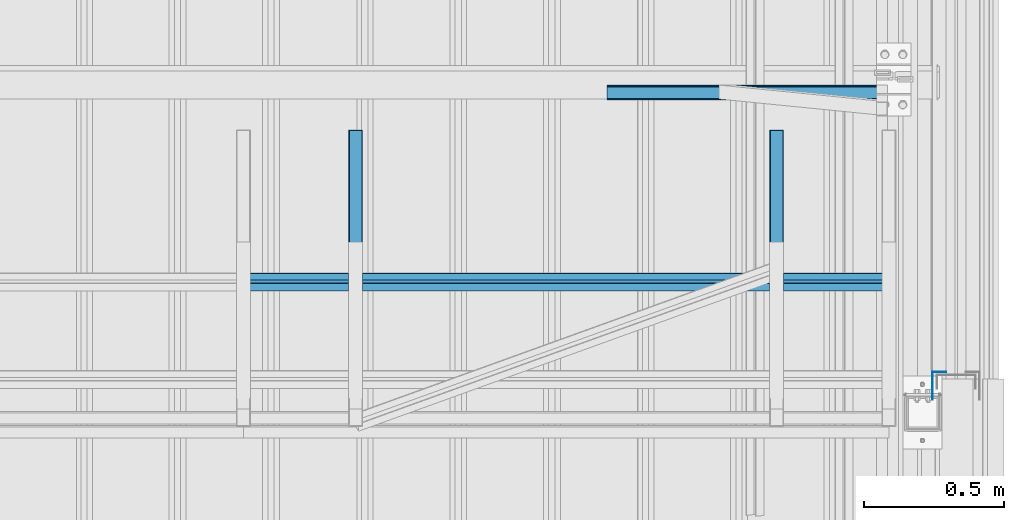
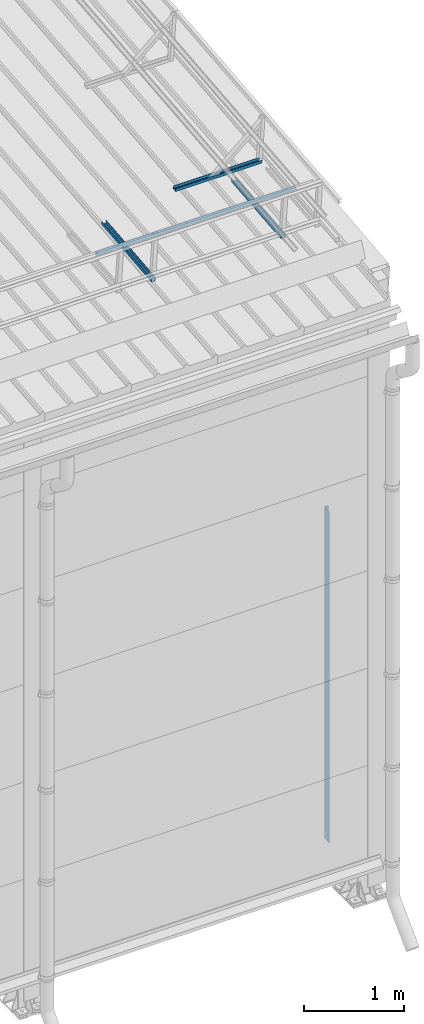
# One storey, part 70 of 709: 5 beams, 5 elements without a shape of their own.
"""IFC4 building model written with IfcOpenShell, lengths in millimetres."""

import ifcopenshell
import ifcopenshell.guid

model = None  # the IFC model being written
_history = None  # IfcOwnerHistory: only IFC2X3 demands one
_inside = {}  # id of a spatial element -> (the spatial element, [elements in it])
_under = {}  # id of a project, library or spatial element -> (it, [spatial elements below it])
_declared = {}  # id of a project -> (the project, [libraries it declares])
_typed = {}  # id of a type object -> (the type object, [elements of that type])
_made_of = {}  # id of a material, layer set ... -> (it, [elements and type objects made of it])


def new_model(schema):
    """Start an empty IFC model of exactly this schema.

    Asked for "IFC4X3", IfcOpenShell would pick the latest addendum, in which some entities
    have other attributes; the version numbers below select the first issue.
    IFC2X3 requires an IfcOwnerHistory on every rooted entity: one is made here for all.
    """
    global model, _history
    if schema == "IFC4X3":
        model = ifcopenshell.file(schema_version=(4, 3, 0, 0))
    else:
        model = ifcopenshell.file(schema=schema)
    _inside.clear()
    _under.clear()
    _declared.clear()
    _typed.clear()
    _made_of.clear()
    _history = None
    if model.schema == "IFC2X3":
        org = make("IfcOrganization", Name="unknown")
        user = make(
            "IfcPersonAndOrganization",
            ThePerson=make("IfcPerson", FamilyName="unknown"),
            TheOrganization=org,
        )
        app = make(
            "IfcApplication",
            ApplicationDeveloper=org,
            Version="unknown",
            ApplicationFullName="unknown",
            ApplicationIdentifier="unknown",
        )
        _history = make(
            "IfcOwnerHistory",
            OwningUser=user,
            OwningApplication=app,
            ChangeAction="ADDED",
            CreationDate=0,
        )
    return model


def make(cls, **values):
    """One entity of the class cls with the attributes given. An attribute that is None is left unset."""
    return model.create_entity(
        cls, **{name: value for name, value in values.items() if value is not None}
    )


def rooted(cls, **values):
    """An entity with a GlobalId (a new one), such as an element, a storey or a relation."""
    return make(cls, GlobalId=ifcopenshell.guid.new(), OwnerHistory=_history, **values)


def si_unit(unit_type, name, prefix=None):
    """IfcSIUnit, for example si_unit("LENGTHUNIT", "METRE", prefix="MILLI")."""
    return make("IfcSIUnit", UnitType=unit_type, Prefix=prefix, Name=name)


def assignment(units):
    """IfcUnitAssignment: the units of a project."""
    return None if units is None else make("IfcUnitAssignment", Units=units)


def point(xyz):
    """IfcCartesianPoint."""
    return None if xyz is None else make("IfcCartesianPoint", Coordinates=xyz)


def direction(xyz):
    """IfcDirection."""
    return None if xyz is None else make("IfcDirection", DirectionRatios=xyz)


def frame(location, z_axis=None, x_axis=None):
    """IfcAxis2Placement3D, a coordinate frame: its origin and axes. An axis left out is left unset."""
    return make(
        "IfcAxis2Placement3D",
        Location=point(location),
        Axis=direction(z_axis),
        RefDirection=direction(x_axis),
    )


def origin_with_axes():
    """The frame at (0, 0, 0) with the z axis (0, 0, 1) and the x axis (1, 0, 0) written out."""
    return frame((0.0, 0.0, 0.0), z_axis=(0.0, 0.0, 1.0), x_axis=(1.0, 0.0, 0.0))


def place(relative_to, where):
    """IfcLocalPlacement: puts the frame where relative to a parent placement (None: the world)."""
    return make(
        "IfcLocalPlacement", PlacementRelTo=relative_to, RelativePlacement=where
    )


def context(
    kind, dimensions, precision=None, world=None, true_north=None, identifier=None
):
    """IfcGeometricRepresentationContext, for example the 3D "Model" context."""
    return make(
        "IfcGeometricRepresentationContext",
        ContextIdentifier=identifier,
        ContextType=kind,
        CoordinateSpaceDimension=dimensions,
        Precision=precision,
        WorldCoordinateSystem=world,
        TrueNorth=true_north,
    )


def subcontext(parent, identifier, kind, view, scale=None):
    """IfcGeometricRepresentationSubContext, for example "Body" below "Model"."""
    return make(
        "IfcGeometricRepresentationSubContext",
        ContextIdentifier=identifier,
        ContextType=kind,
        ParentContext=parent,
        TargetScale=scale,
        TargetView=view,
    )


def project(units=None, contexts=None):
    """IfcProject with its units and contexts."""
    return rooted(
        "IfcProject",
        Name="project",
        RepresentationContexts=contexts,
        UnitsInContext=assignment(units),
    )


def spatial(cls, under=None, at=None, **own):
    """A site, building, storey or space (cls), placed at a placement, below another one or the project."""
    s = rooted(cls, ObjectPlacement=at, **own)
    if under is not None:
        _under.setdefault(under.id(), (under, []))[1].append(s)
    return s


def point_list(points):
    """IfcCartesianPointList2D or 3D."""
    cls = (
        "IfcCartesianPointList2D" if len(points[0]) == 2 else "IfcCartesianPointList3D"
    )
    return make(cls, CoordList=points)


def line(*indices):
    """IfcLineIndex: a straight run through numbered points of an indexed curve."""
    return model.create_entity("IfcLineIndex", indices)


def indexed_curve(points, segments=None, self_intersect=None):
    """IfcIndexedPolyCurve: lines and arcs through numbered points (the first is 1)."""
    return make(
        "IfcIndexedPolyCurve",
        Points=point_list(points),
        Segments=segments,
        SelfIntersect=self_intersect,
    )


def outline(outer, holes=None, kind="AREA"):
    """IfcArbitraryClosedProfileDef: a profile drawn as a closed curve; with holes, ...WithVoids."""
    if holes is None:
        return make("IfcArbitraryClosedProfileDef", ProfileType=kind, OuterCurve=outer)
    return make(
        "IfcArbitraryProfileDefWithVoids",
        ProfileType=kind,
        OuterCurve=outer,
        InnerCurves=holes,
    )


def extrude(swept, where, along, depth):
    """IfcExtrudedAreaSolid: the profile swept, set in the frame where, extruded along a direction by depth."""
    return make(
        "IfcExtrudedAreaSolid",
        SweptArea=swept,
        Position=where,
        ExtrudedDirection=direction(along),
        Depth=depth,
    )


def shape(context_of_items, identifier, shape_type, items):
    """IfcShapeRepresentation: the items that make up one representation, for example the "Body"."""
    return make(
        "IfcShapeRepresentation",
        ContextOfItems=context_of_items,
        RepresentationIdentifier=identifier,
        RepresentationType=shape_type,
        Items=items,
    )


def material(Name=None, Category=None):
    """IfcMaterial."""
    return make("IfcMaterial", Name=Name, Category=Category)


def made_of(thing, what):
    """Note that an element or type object is made of a material, layer set ...; save() writes the relation."""
    if what is not None:
        _made_of.setdefault(what.id(), (what, []))[1].append(thing)
    return thing


def element(
    cls,
    number,
    at=None,
    inside=None,
    cuts=None,
    type_object=None,
    material=None,
    context=None,
    identifier="Body",
    shape_type=None,
    held_by="IfcProductDefinitionShape",
    body=None,
    shapes=None,
    **own,
):
    """One element of the class cls, such as IfcWall. Its Tag is "e" and its number.

    at: its placement. inside: the storey or other place that contains it. cuts: it is an
    opening in that element (IfcRelVoidsElement). A single representation is given by context,
    identifier, shape_type and body (its items); several are given by shapes. held_by: the class
    of the entity that holds the representations. save() writes the other relations.
    """
    e = rooted(cls, Tag="e%d" % number, ObjectPlacement=at, **own)
    if body is not None:
        shapes = [shape(context, identifier, shape_type, body)]
    if shapes is not None:
        e.Representation = make(held_by, Representations=shapes)
    if inside is not None:
        _inside.setdefault(inside.id(), (inside, []))[1].append(e)
    if cuts is not None:
        rooted(
            "IfcRelVoidsElement", RelatingBuildingElement=cuts, RelatedOpeningElement=e
        )
    if type_object is not None:
        _typed.setdefault(type_object.id(), (type_object, []))[1].append(e)
    return made_of(e, material)


def aggregate(whole, parts):
    """IfcRelAggregates: a whole, such as a stair, and the parts it consists of."""
    return rooted("IfcRelAggregates", RelatingObject=whole, RelatedObjects=parts)


def save(model, path):
    """Write the relations noted so far, then the file.

    IfcRelAggregates (storeys below a building ...), IfcRelContainedInSpatialStructure (elements
    in a storey), IfcRelDefinesByType, IfcRelAssociatesMaterial and IfcRelDeclares: one each for
    every whole, place, type object, material and project.
    """
    for whole, parts in _under.values():
        aggregate(whole, parts)
    for where, things in _inside.values():
        rooted(
            "IfcRelContainedInSpatialStructure",
            RelatedElements=things,
            RelatingStructure=where,
        )
    for kind, things in _typed.values():
        rooted("IfcRelDefinesByType", RelatedObjects=things, RelatingType=kind)
    for what, things in _made_of.values():
        rooted("IfcRelAssociatesMaterial", RelatedObjects=things, RelatingMaterial=what)
    for by, libraries in _declared.values():
        rooted("IfcRelDeclares", RelatingContext=by, RelatedDefinitions=libraries)
    model.write(path)


model = new_model("IFC4")

# Units and contexts
model_context = context("Model", 3, precision=0.2, world=origin_with_axes(), true_north=direction((0.0, 1.0)))
body_context = subcontext(model_context, "Body", "Model", "MODEL_VIEW")
ifc_project = project(units=[si_unit("LENGTHUNIT", "METRE", prefix="MILLI"), si_unit("AREAUNIT", "SQUARE_METRE"), si_unit("VOLUMEUNIT", "CUBIC_METRE"), si_unit("MASSUNIT", "GRAM", prefix="KILO"), si_unit("TIMEUNIT", "SECOND"), si_unit("PLANEANGLEUNIT", "RADIAN"), si_unit("SOLIDANGLEUNIT", "STERADIAN"), si_unit("THERMODYNAMICTEMPERATUREUNIT", "DEGREE_CELSIUS"), si_unit("LUMINOUSINTENSITYUNIT", "LUMEN")], contexts=[model_context])

# Site, building, storey
site_placement = place(None, origin_with_axes())
site = spatial("IfcSite", under=ifc_project, at=site_placement, CompositionType="ELEMENT")
building_placement = place(site_placement, origin_with_axes())
building = spatial("IfcBuilding", under=site, at=building_placement, Name="Undefined", CompositionType="ELEMENT")
storey_placement = place(building_placement, origin_with_axes())
storey = spatial("IfcBuildingStorey", under=building, at=storey_placement, Name="Undefined", CompositionType="ELEMENT", Elevation=0.0)

# Assembly, beam
assembly_1_placement = place(storey_placement, frame((47920.0, 768.92298, 7577.16191), z_axis=(0.0, -0.099503719, 0.9950371902), x_axis=(0.0, 0.9950371902, 0.099503719)))
assembly_1 = element("IfcElementAssembly", 1, at=assembly_1_placement, inside=storey)
ifc_material = material(Name="Steel_Undefined", Category="STEEL")
beam_1_placement = place(assembly_1_placement, origin_with_axes())
beam_1 = element("IfcBeam", 2, at=beam_1_placement, material=ifc_material, ObjectType="601", context=body_context, shape_type="SolidModel", body=[
    extrude(outline(indexed_curve([(-20.0, -25.0), (20.0, -25.0), (20.0, -22.5), (-17.5, -22.5), (-17.5, 22.5), (20.0, 22.5), (20.0, 25.0), (-20.0, 25.0)], segments=[line(1, 2, 3, 4, 5, 6, 7, 8, 1)])), frame((0.0, 0.0, 0.0), z_axis=(-1.0, 0.0, 0.0), x_axis=(0.0, 0.0, 1.0)), (0.0, 0.0, -1.0), 1000.0),
])
aggregate(assembly_1, [beam_1])

assembly_2_placement = place(storey_placement, frame((49420.0, 768.92298, 7577.16191), z_axis=(0.0, -0.099503719, 0.9950371902), x_axis=(0.0, 0.9950371902, 0.099503719)))
assembly_2 = element("IfcElementAssembly", 3, at=assembly_2_placement, inside=storey)
beam_2_placement = place(assembly_2_placement, origin_with_axes())
beam_2 = element("IfcBeam", 4, at=beam_2_placement, material=ifc_material, ObjectType="601", context=body_context, shape_type="SolidModel", body=[
    extrude(outline(indexed_curve([(-20.0, -25.0), (20.0, -25.0), (20.0, -22.5), (-17.5, -22.5), (-17.5, 22.5), (20.0, 22.5), (20.0, 25.0), (-20.0, 25.0)], segments=[line(1, 2, 3, 4, 5, 6, 7, 8, 1)])), frame((0.0, 0.0, 0.0), z_axis=(-1.0, 0.0, 0.0), x_axis=(0.0, 0.0, 1.0)), (0.0, 0.0, -1.0), 1000.0),
])
aggregate(assembly_2, [beam_2])

assembly_3_placement = place(storey_placement, frame((47520.0, 1225.80867, 7759.0901), z_axis=(0.0, 0.6332377902, 0.7739572992), x_axis=(1.0, 0.0, 0.0)))
assembly_3 = element("IfcElementAssembly", 5, at=assembly_3_placement, inside=storey)
beam_3_placement = place(assembly_3_placement, origin_with_axes())
beam_3 = element("IfcBeam", 6, at=beam_3_placement, material=ifc_material, ObjectType="607", context=body_context, shape_type="SolidModel", body=[
    extrude(outline(indexed_curve([(-20.0, -25.0), (20.0, -25.0), (20.0, -22.5), (-17.5, -22.5), (-17.5, 22.5), (20.0, 22.5), (20.0, 25.0), (-20.0, 25.0)], segments=[line(1, 2, 3, 4, 5, 6, 7, 8, 1)])), frame((0.0, 0.0, 0.0), z_axis=(-1.0, 0.0, 0.0), x_axis=(0.0, 0.0, 1.0)), (0.0, 0.0, -1.0), 2300.0),
])
aggregate(assembly_3, [beam_3])

assembly_4_placement = place(storey_placement, frame((49815.0, 1899.83375, 7690.25299), z_axis=(0.0, -0.099503719, 0.9950371902), x_axis=(-1.0, 0.0, 0.0)))
assembly_4 = element("IfcElementAssembly", 7, at=assembly_4_placement, inside=storey)
beam_4_placement = place(assembly_4_placement, origin_with_axes())
beam_4 = element("IfcBeam", 8, at=beam_4_placement, material=ifc_material, ObjectType="601", context=body_context, shape_type="SolidModel", body=[
    extrude(outline(indexed_curve([(-20.0, -25.0), (20.0, -25.0), (20.0, -22.5), (-17.5, -22.5), (-17.5, 22.5), (20.0, 22.5), (20.0, 25.0), (-20.0, 25.0)], segments=[line(1, 2, 3, 4, 5, 6, 7, 8, 1)])), frame((0.0, 0.0, 0.0), z_axis=(-1.0, 0.0, 0.0), x_axis=(0.0, 0.0, 1.0)), (0.0, 0.0, -1.0), 1000.0),
])
aggregate(assembly_4, [beam_4])

assembly_5_placement = place(storey_placement, frame((49999.0, 905.0, 4000.0), z_axis=(-1.0, 0.0, 0.0), x_axis=(0.0, 0.0, -1.0)))
assembly_5 = element("IfcElementAssembly", 9, at=assembly_5_placement, inside=storey)
beam_5_placement = place(assembly_5_placement, origin_with_axes())
beam_5 = element("IfcBeam", 10, at=beam_5_placement, material=ifc_material, context=body_context, shape_type="SolidModel", body=[
    extrude(outline(indexed_curve([(-25.0, -1.0), (25.0, -1.0), (25.0, 99.0), (23.0, 99.0), (23.0, 1.0), (-25.0, 1.0)], segments=[line(1, 2, 3, 4, 5, 6, 1)])), frame((0.0, 0.0, 0.0), z_axis=(-1.0, 0.0, 0.0), x_axis=(0.0, 0.0, 1.0)), (0.0, 0.0, -1.0), 4050.0),
])
aggregate(assembly_5, [beam_5])

save(model, "model.ifc")
